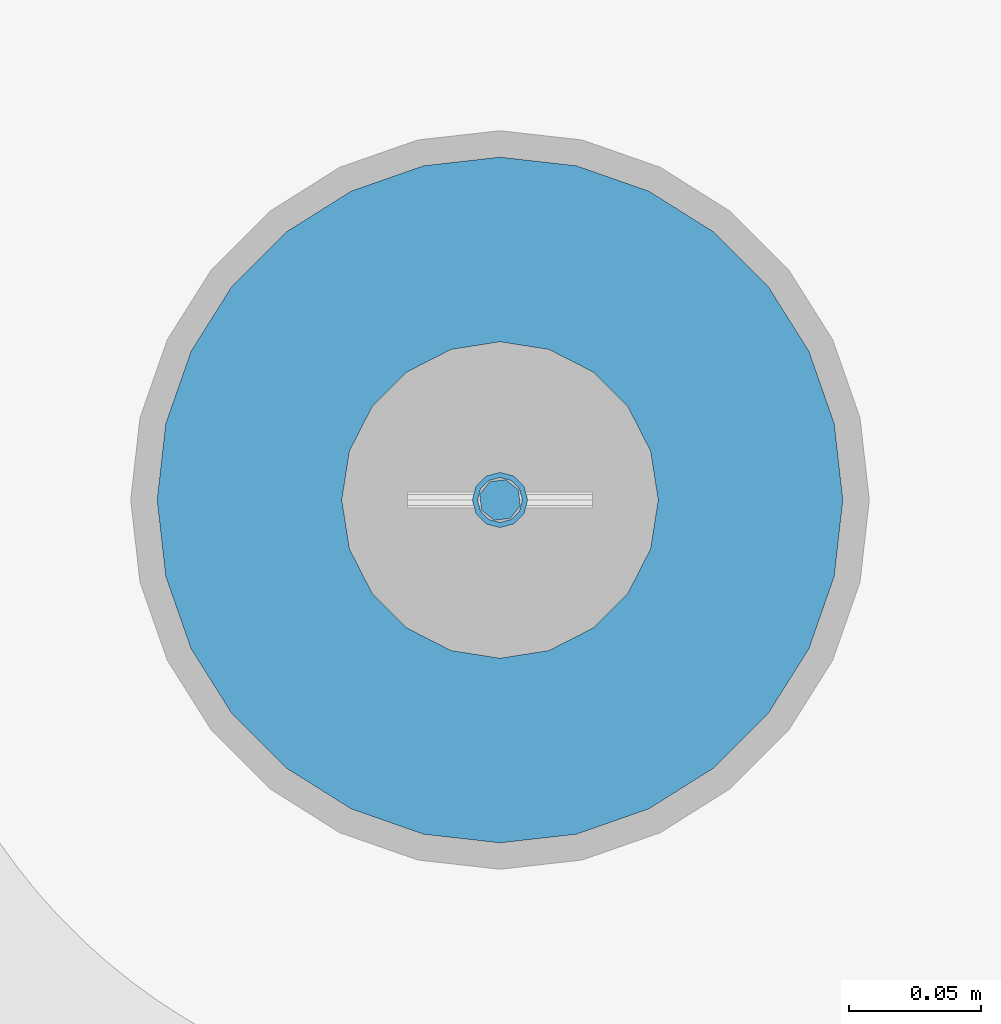
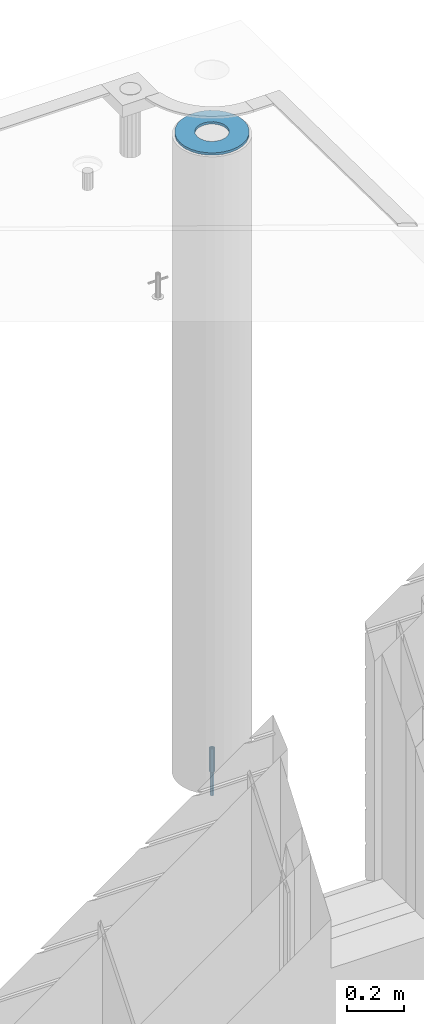
# One storey, part 37 of 341: 3 columns, 3 elements without a shape of their own.
"""IFC2X3 building model written with IfcOpenShell, lengths in millimetres."""

from ifc_helpers import new_model, si_unit, frame, origin_with_axes, place, context, subcontext, project, spatial, faceted_brep, material, type_object, element, aggregate, save


model = new_model("IFC2X3")

# Units and contexts
model_context = context("Model", 3, precision=1e-05, world=origin_with_axes())
body_context = subcontext(model_context, "Body", "Model", "MODEL_VIEW")
ifc_project = project(units=[si_unit("LENGTHUNIT", "METRE", prefix="MILLI"), si_unit("AREAUNIT", "SQUARE_METRE"), si_unit("VOLUMEUNIT", "CUBIC_METRE"), si_unit("MASSUNIT", "GRAM", prefix="KILO"), si_unit("TIMEUNIT", "SECOND"), si_unit("PLANEANGLEUNIT", "RADIAN"), si_unit("SOLIDANGLEUNIT", "STERADIAN"), si_unit("THERMODYNAMICTEMPERATUREUNIT", "DEGREE_CELSIUS"), si_unit("LUMINOUSINTENSITYUNIT", "LUMEN")], contexts=[model_context])

# Site, building, storey
site_placement = place(None, origin_with_axes())
site = spatial("IfcSite", under=ifc_project, at=site_placement, CompositionType="ELEMENT")
building_placement = place(site_placement, origin_with_axes())
building = spatial("IfcBuilding", under=site, at=building_placement, CompositionType="ELEMENT")
storey_placement = place(building_placement, origin_with_axes())
storey = spatial("IfcBuildingStorey", under=building, at=storey_placement, Name="5", CompositionType="ELEMENT", Elevation=0.0)

# Assemblies, columns
assembly_1_placement = place(storey_placement, origin_with_axes())
assembly_1 = element("IfcElementAssembly", 1, at=assembly_1_placement, inside=storey, AssemblyPlace="NOTDEFINED", PredefinedType="REINFORCEMENT_UNIT")
assembly_2_placement = place(assembly_1_placement, origin_with_axes())
assembly_2 = element("IfcElementAssembly", 2, at=assembly_2_placement, Name="Steel Assembly", AssemblyPlace="NOTDEFINED", PredefinedType="RIGID_FRAME")
ifc_material_1 = material(Name="STEEL/S235JR")
column_type_1 = type_object("IfcColumnType", Name="D16", PredefinedType="NOTDEFINED")
column_1_placement = place(assembly_2_placement, frame((35010.0004801435, 22669.9842012047, 93625.0), z_axis=(-0.261346946111888, -0.96524492941325, 0.0), x_axis=(0.0, 0.0, 1.0)))
column_1 = element("IfcColumn", 3, at=column_1_placement, type_object=column_type_1, material=ifc_material_1, Name="M16", ObjectType="D16", context=body_context, shape_type="Brep", body=[
    faceted_brep([(0.0, -8.0, 0.0), (0.0, -5.65685424949334, -5.65685424949334), (150.0, -5.65685424949697, -5.65685424949334), (150.0, -8.00000000000364, 0.0), (0.0, 0.0, -8.0), (150.0, -7.27595761418343e-12, -7.99999999999636), (0.0, 5.65685424949334, -5.65685424949334), (150.0, 5.6568542494897, -5.65685424949334), (0.0, 8.0, 0.0), (150.0, 8.0, -3.63797880709171e-12), (0.0, 5.65685424949334, 5.65685424949334), (150.0, 5.65685424949334, 5.65685424949697), (0.0, 0.0, 8.0), (150.0, -3.63797880709171e-12, 8.0), (0.0, -5.65685424949334, 5.65685424949334), (150.0, -5.65685424949334, 5.6568542494897)], [[[0, 1, 2, 3]], [[1, 4, 5, 2]], [[4, 6, 7, 5]], [[6, 8, 9, 7]], [[8, 10, 11, 9]], [[10, 12, 13, 11]], [[12, 14, 15, 13]], [[14, 0, 3, 15]], [[5, 7, 9, 11, 13, 15, 3, 2]], [[14, 12, 10, 8, 6, 4, 1, 0]]]),
])
aggregate(assembly_2, [column_1])
assembly_3_placement = place(assembly_1_placement, origin_with_axes())
assembly_3 = element("IfcElementAssembly", 4, at=assembly_3_placement, Name="Steel Assembly", AssemblyPlace="NOTDEFINED", PredefinedType="RIGID_FRAME")
ifc_material_2 = material(Name="STEEL/Steel_Undefined")
column_type_2 = type_object("IfcColumnType", PredefinedType="NOTDEFINED")
column_2_placement = place(assembly_3_placement, frame((35009.9987952044, 22669.984888838, 93725.0), z_axis=(0.0, 1.0, 0.0), x_axis=(0.0, 0.0, 1.0)))
column_2 = element("IfcColumn", 5, at=column_2_placement, type_object=column_type_2, material=ifc_material_2, context=body_context, shape_type="Brep", body=[
    faceted_brep([(0.0, -8.49999999999272, -1.45519152283669e-11), (0.0, -7.36121593215648, 4.24999999998545), (100.000000000262, -7.36121593215648, 4.24999999998545), (100.000000000262, -8.49999999999272, -1.45519152283669e-11), (0.0, -4.24999999998545, 7.36121593216376), (100.000000000262, -4.24999999998545, 7.36121593216376), (0.0, 1.45519152283669e-11, 8.49999999998545), (100.000000000262, 1.45519152283669e-11, 8.49999999998545), (0.0, 4.25000000001455, 7.36121593216376), (100.000000000262, 4.25000000001455, 7.36121593216376), (0.0, 7.36121593217104, 4.24999999998545), (100.000000000262, 7.36121593217104, 4.24999999998545), (0.0, 8.50000000000728, 0.0), (100.000000000262, 8.50000000000728, 0.0), (0.0, 7.36121593217104, -4.25000000001455), (100.000000000262, 7.36121593217104, -4.25000000001455), (0.0, 4.25000000000728, -7.36121593219286), (100.000000000262, 4.25000000000728, -7.36121593219286), (0.0, 7.27595761418343e-12, -8.5), (100.000000000262, 7.27595761418343e-12, -8.5), (0.0, -4.24999999999272, -7.36121593217831), (100.000000000262, -4.24999999999272, -7.36121593217831), (0.0, -7.36121593215648, -4.25), (100.000000000262, -7.36121593215648, -4.25), (0.0, -10.4999999999927, -1.45519152283669e-11), (0.0, -9.09326673972828, -5.25000000001455), (100.000000000262, -9.09326673972828, -5.25000000001455), (100.000000000262, -10.4999999999927, -1.45519152283669e-11), (0.0, -5.24999999998545, -9.09326673974283), (100.000000000262, -5.24999999998545, -9.09326673974283), (0.0, 7.27595761418343e-12, -10.5), (100.000000000262, 7.27595761418343e-12, -10.5), (0.0, 5.25000000001455, -9.09326673975738), (100.000000000262, 5.25000000001455, -9.09326673975738), (0.0, 9.09326673975011, -5.25000000001455), (100.000000000262, 9.09326673975011, -5.25000000001455), (0.0, 10.5000000000073, -1.45519152283669e-11), (100.000000000262, 10.5000000000073, -1.45519152283669e-11), (0.0, 9.09326673975011, 5.25), (100.000000000262, 9.09326673975011, 5.25), (0.0, 5.25000000000728, 9.09326673972828), (100.000000000262, 5.25000000000728, 9.09326673972828), (0.0, 1.45519152283669e-11, 10.4999999999854), (100.000000000262, 1.45519152283669e-11, 10.4999999999854), (0.0, -5.24999999999272, 9.09326673972828), (100.000000000262, -5.24999999999272, 9.09326673972828), (0.0, -9.09326673972828, 5.24999999998545), (100.000000000262, -9.09326673972828, 5.24999999998545)], [[[0, 1, 2, 3]], [[1, 4, 5, 2]], [[4, 6, 7, 5]], [[6, 8, 9, 7]], [[8, 10, 11, 9]], [[10, 12, 13, 11]], [[12, 14, 15, 13]], [[14, 16, 17, 15]], [[16, 18, 19, 17]], [[18, 20, 21, 19]], [[20, 22, 23, 21]], [[22, 0, 3, 23]], [[24, 25, 26, 27]], [[25, 28, 29, 26]], [[28, 30, 31, 29]], [[30, 32, 33, 31]], [[32, 34, 35, 33]], [[34, 36, 37, 35]], [[36, 38, 39, 37]], [[38, 40, 41, 39]], [[40, 42, 43, 41]], [[42, 44, 45, 43]], [[44, 46, 47, 45]], [[46, 24, 27, 47]], [[29, 31, 33, 35, 37, 39, 41, 43, 45, 47, 27, 26], [5, 7, 9, 11, 13, 15, 17, 19, 21, 23, 3, 2]], [[46, 44, 42, 40, 38, 36, 34, 32, 30, 28, 25, 24], [22, 20, 18, 16, 14, 12, 10, 8, 6, 4, 1, 0]]]),
])
aggregate(assembly_3, [column_2])
ifc_material_3 = material()
column_type_3 = type_object("IfcColumnType", Name="D260", PredefinedType="NOTDEFINED")
column_3_placement = place(assembly_1_placement, frame((35009.9987952044, 22669.984888838, 96435.0), z_axis=(-1.0, 3.00000001838171e-08, 0.0), x_axis=(0.0, 0.0, 1.0)))
column_3 = element("IfcColumn", 6, at=column_3_placement, type_object=column_type_3, material=ifc_material_3, Name="60", ObjectType="D260", context=body_context, shape_type="Brep", body=[
    faceted_brep([(10.0, -18.541019662498, -57.0633909777098), (0.0, -18.541019662498, -57.0633909777098), (0.0, -35.2671151375471, -48.5410196624944), (10.0, -35.2671151375471, -48.5410196624944), (0.0, -48.541019662498, -35.2671151375471), (10.0, -48.541019662498, -35.2671151375471), (0.0, -57.0633909777098, -18.5410196624944), (10.0, -57.0633909777098, -18.5410196624944), (0.0, -60.0, 0.0), (10.0, -60.0, 0.0), (0.0, -57.0633909777098, 18.5410196624944), (10.0, -57.0633909777098, 18.5410196624944), (0.0, -48.541019662498, 35.2671151375471), (10.0, -48.541019662498, 35.2671151375471), (0.0, -35.2671151375471, 48.5410196624944), (10.0, -35.2671151375471, 48.5410196624944), (0.0, -18.541019662498, 57.0633909777098), (10.0, -18.541019662498, 57.0633909777098), (0.0, 0.0, 60.0), (10.0, 0.0, 60.0), (0.0, 18.541019662498, 57.0633909777098), (10.0, 18.541019662498, 57.0633909777098), (0.0, 35.2671151375471, 48.5410196624944), (10.0, 35.2671151375471, 48.5410196624944), (0.0, 48.541019662498, 35.2671151375471), (10.0, 48.541019662498, 35.2671151375471), (0.0, 57.0633909777098, 18.5410196624944), (10.0, 57.0633909777098, 18.5410196624944), (0.0, 60.0, 0.0), (10.0, 60.0, 0.0), (0.0, 57.0633909777098, -18.5410196624944), (10.0, 57.0633909777098, -18.5410196624944), (0.0, 48.541019662498, -35.2671151375471), (10.0, 48.541019662498, -35.2671151375471), (0.0, 35.2671151375471, -48.5410196624944), (10.0, 35.2671151375471, -48.5410196624944), (0.0, 18.541019662498, -57.0633909777098), (10.0, 18.541019662498, -57.0633909777098), (0.0, 0.0, -60.0), (10.0, 0.0, -60.0), (0.0, -126.740628583637, -28.9277214143222), (0.0, -117.125952827315, -56.4048860852854), (10.0, -117.125952827315, -56.4048860852854), (10.0, -126.740628583637, -28.9277214143222), (0.0, -101.638092720845, -81.0536742416371), (10.0, -101.638092720845, -81.0536742416371), (0.0, -81.0536742416371, -101.638092720845), (10.0, -81.0536742416371, -101.638092720845), (0.0, -56.4048860852818, -117.125952827315), (10.0, -56.4048860852818, -117.125952827315), (0.0, -28.9277214143222, -126.740628583641), (10.0, -28.9277214143222, -126.740628583641), (0.0, 0.0, -130.0), (10.0, 0.0, -130.0), (0.0, 28.9277214143222, -126.740628583641), (10.0, 28.9277214143222, -126.740628583641), (0.0, 56.4048860852818, -117.125952827315), (10.0, 56.4048860852818, -117.125952827315), (0.0, 81.0536742416371, -101.638092720845), (10.0, 81.0536742416371, -101.638092720845), (0.0, 101.638092720845, -81.0536742416371), (10.0, 101.638092720845, -81.0536742416371), (0.0, 117.125952827315, -56.4048860852854), (10.0, 117.125952827315, -56.4048860852854), (0.0, 126.740628583637, -28.9277214143222), (10.0, 126.740628583637, -28.9277214143222), (0.0, 130.0, -1.81898940354586e-12), (10.0, 130.0, 0.0), (0.0, 126.740628583637, 28.9277214143222), (10.0, 126.740628583637, 28.9277214143222), (0.0, 117.125952827315, 56.4048860852854), (10.0, 117.125952827315, 56.4048860852854), (0.0, 101.638092720845, 81.0536742416371), (10.0, 101.638092720845, 81.0536742416371), (0.0, 81.0536742416371, 101.638092720845), (10.0, 81.0536742416371, 101.638092720845), (0.0, 56.4048860852818, 117.125952827315), (10.0, 56.4048860852818, 117.125952827315), (0.0, 28.9277214143222, 126.740628583641), (10.0, 28.9277214143222, 126.740628583641), (0.0, 0.0, 130.0), (10.0, 0.0, 130.0), (0.0, -28.9277214143222, 126.740628583641), (10.0, -28.9277214143222, 126.740628583641), (0.0, -56.4048860852818, 117.125952827315), (10.0, -56.4048860852818, 117.125952827315), (0.0, -81.0536742416371, 101.638092720845), (10.0, -81.0536742416371, 101.638092720845), (0.0, -101.638092720845, 81.0536742416371), (10.0, -101.638092720845, 81.0536742416371), (0.0, -117.125952827315, 56.4048860852854), (10.0, -117.125952827315, 56.4048860852854), (0.0, -126.740628583637, 28.9277214143222), (10.0, -126.740628583637, 28.9277214143222), (0.0, -130.0, -3.63797880709171e-12), (10.0, -130.0, 0.0)], [[[0, 1, 2, 3]], [[3, 2, 4, 5]], [[5, 4, 6, 7]], [[7, 6, 8, 9]], [[9, 8, 10, 11]], [[11, 10, 12, 13]], [[13, 12, 14, 15]], [[15, 14, 16, 17]], [[17, 16, 18, 19]], [[19, 18, 20, 21]], [[21, 20, 22, 23]], [[23, 22, 24, 25]], [[25, 24, 26, 27]], [[27, 26, 28, 29]], [[29, 28, 30, 31]], [[31, 30, 32, 33]], [[33, 32, 34, 35]], [[35, 34, 36, 37]], [[37, 36, 38, 39]], [[39, 38, 1, 0]], [[40, 41, 42, 43]], [[41, 44, 45, 42]], [[44, 46, 47, 45]], [[46, 48, 49, 47]], [[48, 50, 51, 49]], [[50, 52, 53, 51]], [[52, 54, 55, 53]], [[54, 56, 57, 55]], [[56, 58, 59, 57]], [[58, 60, 61, 59]], [[60, 62, 63, 61]], [[62, 64, 65, 63]], [[64, 66, 67, 65]], [[66, 68, 69, 67]], [[68, 70, 71, 69]], [[70, 72, 73, 71]], [[72, 74, 75, 73]], [[74, 76, 77, 75]], [[76, 78, 79, 77]], [[78, 80, 81, 79]], [[80, 82, 83, 81]], [[82, 84, 85, 83]], [[84, 86, 87, 85]], [[86, 88, 89, 87]], [[88, 90, 91, 89]], [[90, 92, 93, 91]], [[92, 94, 95, 93]], [[42, 45, 47, 49, 51, 53, 55, 57, 59, 61, 63, 65, 67, 69, 71, 73, 75, 77, 79, 81, 83, 85, 87, 89, 91, 93, 95, 43], [3, 5, 7, 9, 11, 13, 15, 17, 19, 21, 23, 25, 27, 29, 31, 33, 35, 37, 39, 0]], [[94, 40, 43, 95]], [[92, 90, 88, 86, 84, 82, 80, 78, 76, 74, 72, 70, 68, 66, 64, 62, 60, 58, 56, 54, 52, 50, 48, 46, 44, 41, 40, 94], [34, 32, 30, 28, 26, 24, 22, 20, 18, 16, 14, 12, 10, 8, 6, 4, 2, 1, 38, 36]]]),
])
aggregate(assembly_1, [assembly_3, assembly_2, column_3])

save(model, "model.ifc")
